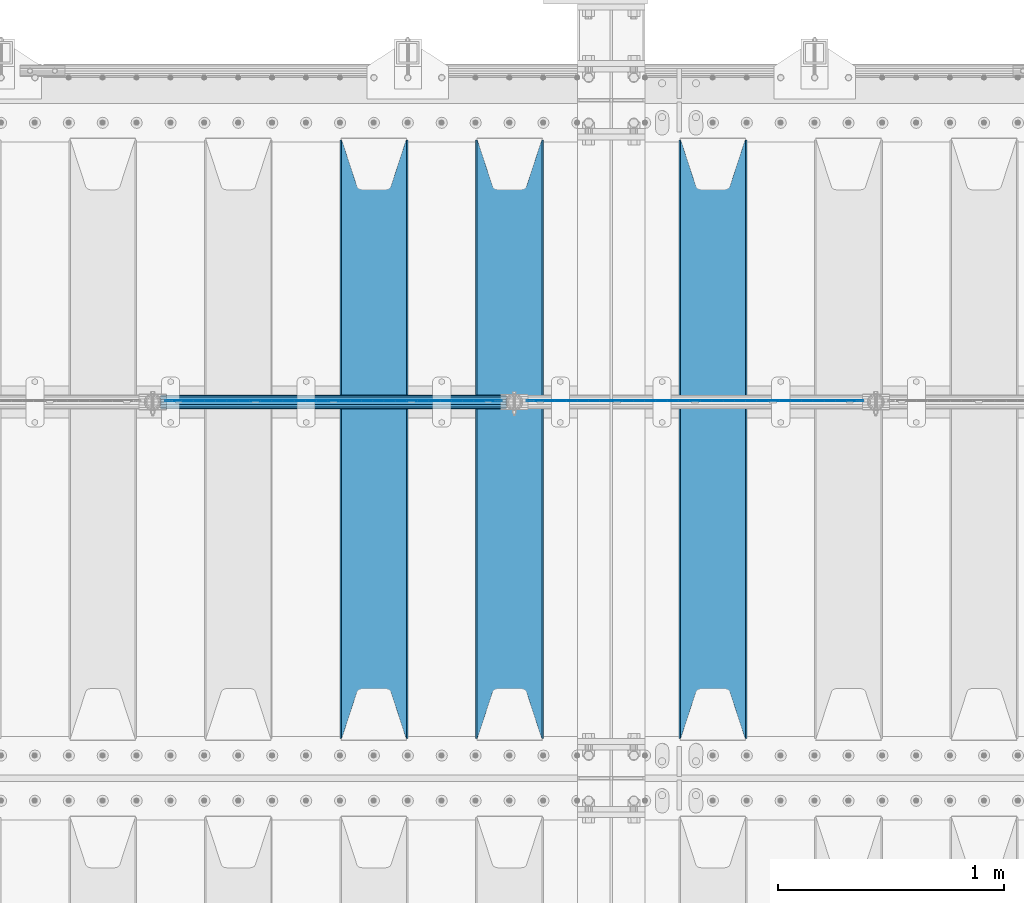
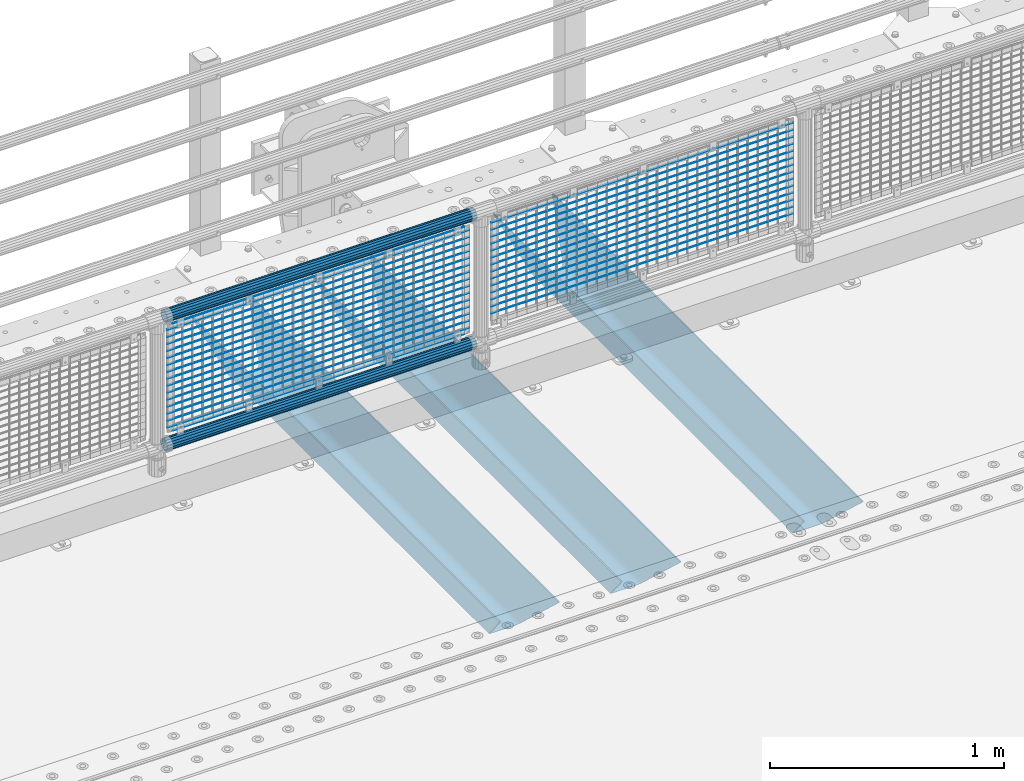
# One storey, part 127 of 247: 36 beams.
"""IFC2X3 building model written with IfcOpenShell, lengths in millimetres."""

from ifc_helpers import new_model, si_unit, frame, origin_with_axes, place, context, subcontext, project, spatial, faceted_brep, material, type_object, element, save


model = new_model("IFC2X3")

# Units and contexts
model_context = context("Model", 3, precision=1e-05, world=origin_with_axes())
body_context = subcontext(model_context, "Body", "Model", "MODEL_VIEW")
ifc_project = project(units=[si_unit("LENGTHUNIT", "METRE", prefix="MILLI"), si_unit("AREAUNIT", "SQUARE_METRE"), si_unit("VOLUMEUNIT", "CUBIC_METRE"), si_unit("MASSUNIT", "GRAM", prefix="KILO"), si_unit("TIMEUNIT", "SECOND"), si_unit("PLANEANGLEUNIT", "RADIAN"), si_unit("SOLIDANGLEUNIT", "STERADIAN"), si_unit("THERMODYNAMICTEMPERATUREUNIT", "DEGREE_CELSIUS"), si_unit("LUMINOUSINTENSITYUNIT", "LUMEN")], contexts=[model_context])

# Site, building, storey
site_placement = place(None, origin_with_axes())
site = spatial("IfcSite", under=ifc_project, at=site_placement, CompositionType="ELEMENT")
building_placement = place(site_placement, origin_with_axes())
building = spatial("IfcBuilding", under=site, at=building_placement, Name="Standard", CompositionType="ELEMENT")
storey_placement = place(building_placement, origin_with_axes())
storey = spatial("IfcBuildingStorey", under=building, at=storey_placement, Name="Undefined", CompositionType="ELEMENT", Elevation=0.0)

# Beams
ifc_material_1 = material(Name="STEEL/S355N")
beam_type_1 = type_object("IfcBeamType", PredefinedType="NOTDEFINED")
beam_1_placement = place(storey_placement, frame((12700.0, 6175.0, -115.0), z_axis=(0.0, 0.0, 1.0), x_axis=(0.0, 1.0, 0.0)))
element("IfcBeam", 1, at=beam_1_placement, inside=storey, type_object=beam_type_1, material=ifc_material_1, context=body_context, shape_type="Brep", body=[
    faceted_brep([(0.0, 150.0, 115.0), (0.0, 143.689999999999, 115.0), (2650.00000000297, 143.689999999999, 115.0), (2650.00000000297, 150.0, 115.0), (2650.00000000297, 142.059565218402, 110.0000000031), (2650.00000000297, 148.369565218403, 110.0000000031), (2441.90079219208, -80.1103600731112, -98.0992078077845), (2437.7588105432, -77.5672621345584, -102.241189456673), (2434.06523489746, -74.4080125315522, -105.934765102404), (2430.91086095089, -70.710272125576, -109.089139048974), (2428.37322971128, -66.5649389910068, -111.626770288588), (2426.51472138054, -62.0739139532889, -113.485278619323), (2425.38102192091, -57.3475956567672, -114.618978078955), (2424.99999999987, -52.5021667386536, -115.0), (2424.99999999987, 52.5021667386536, -115.0), (2425.38102192091, 57.3475956567672, -114.618978078955), (2426.51472138054, 62.0739139532889, -113.485278619323), (2428.37322971128, 66.5649389910068, -111.626770288588), (2430.91086095089, 70.710272125576, -109.089139048974), (2434.06523489746, 74.4080125315522, -105.934765102404), (2437.7588105432, 77.5672621345584, -102.241189456673), (2441.90079219208, 80.1103600731112, -98.0992078077846), (2446.38936140511, 81.9747917625791, -93.6106385947584), (2448.24948500409, 76.2713538057251, -91.7505149957729), (2444.62967112262, 74.76777986261, -95.3703288772456), (2441.28936334126, 72.7168944282894, -98.710636658607), (2438.31067330438, 70.1691124903846, -101.689326695487), (2435.76682334747, 67.1870637758839, -104.233176652398), (2433.72034654133, 63.8440531834895, -106.279653458539), (2432.22154950041, 60.222258798236, -107.778450499454), (2431.30727574265, 56.4107117849089, -108.692724257221), (2430.99999999987, 52.5031078186876, -109.0), (2430.99999999987, -52.5031078186876, -109.0), (2431.30727574265, -56.4107117849089, -108.692724257221), (2432.22154950041, -60.222258798236, -107.778450499454), (2433.72034654133, -63.8440531834895, -106.279653458539), (2435.76682334747, -67.1870637758839, -104.233176652398), (2438.31067330438, -70.1691124903846, -101.689326695487), (2441.28936334126, -72.7168944282894, -98.7106366586071), (2444.62967112262, -74.76777986261, -95.3703288772457), (2448.24948500409, -76.2713538057251, -91.7505149957729), (2650.00000000297, -142.059565218402, 110.0000000031), (2650.00000000297, -148.369565218403, 110.0000000031), (2446.38936140511, -81.9747917625791, -93.6106385947584), (2650.00000000297, -143.689999999999, 115.0), (2650.00000000297, -150.0, 115.0), (0.0, -143.689999999999, 115.0), (0.0, -150.0, 115.0), (0.0, -148.369565218261, 110.000000002663), (203.610638597422, -81.9747917625791, -93.6106385947584), (208.099207810448, -80.1103600731112, -98.0992078077845), (212.241189459336, -77.5672621345584, -102.241189456673), (215.934765105068, -74.4080125315522, -105.934765102404), (219.089139051637, -70.710272125576, -109.089139048974), (221.626770291251, -66.5649389910068, -111.626770288588), (223.485278621985, -62.0739139532889, -113.485278619323), (224.618978081617, -57.3475956567672, -114.618978078955), (225.000000002663, -52.5021667386536, -115.0), (225.000000002663, 52.5021667386536, -115.0), (224.618978081617, 57.3475956567672, -114.618978078955), (223.485278621985, 62.0739139532889, -113.485278619323), (221.626770291251, 66.5649389910068, -111.626770288588), (219.089139051637, 70.710272125576, -109.089139048974), (215.934765105068, 74.4080125315522, -105.934765102404), (212.241189459336, 77.5672621345584, -102.241189456673), (208.099207810448, 80.1103600731112, -98.0992078077846), (203.610638597422, 81.9747917625791, -93.6106385947584), (0.0, 148.369565218261, 110.000000002663), (0.0, 142.05956521826, 110.000000002663), (201.750514998436, 76.2713538057251, -91.7505149957729), (205.370328879908, 74.76777986261, -95.3703288772456), (208.710636661271, 72.7168944282894, -98.710636658607), (211.68932669815, 70.1691124903846, -101.689326695487), (214.233176655061, 67.1870637758839, -104.233176652398), (216.279653461202, 63.8440531834895, -106.279653458539), (217.778450502117, 60.222258798236, -107.778450499454), (218.692724259885, 56.4107117849089, -108.692724257221), (219.000000002663, 52.5031078186876, -109.0), (219.000000002663, -52.5031078186876, -109.0), (218.692724259885, -56.4107117849089, -108.692724257221), (217.778450502117, -60.222258798236, -107.778450499454), (216.279653461202, -63.8440531834895, -106.279653458539), (214.233176655061, -67.1870637758839, -104.233176652398), (211.68932669815, -70.1691124903846, -101.689326695487), (208.710636661271, -72.7168944282894, -98.7106366586071), (205.370328879908, -74.76777986261, -95.3703288772457), (201.750514998436, -76.2713538057251, -91.7505149957729), (0.0, -142.05956521826, 110.000000002663)], [[[0, 1, 2, 3]], [[3, 2, 4, 5]], [[6, 7, 8, 9, 10, 11, 12, 13, 14, 15, 16, 17, 18, 19, 20, 21, 22, 5, 4, 23, 24, 25, 26, 27, 28, 29, 30, 31, 32, 33, 34, 35, 36, 37, 38, 39, 40, 41, 42, 43]], [[44, 45, 42, 41]], [[46, 47, 45, 44]], [[43, 42, 45, 47, 48, 49]], [[6, 43, 49, 50]], [[7, 6, 50, 51]], [[8, 7, 51, 52]], [[9, 8, 52, 53]], [[10, 9, 53, 54]], [[11, 10, 54, 55]], [[12, 11, 55, 56]], [[13, 12, 56, 57]], [[14, 13, 57, 58]], [[15, 14, 58, 59]], [[16, 15, 59, 60]], [[17, 16, 60, 61]], [[18, 17, 61, 62]], [[19, 18, 62, 63]], [[20, 19, 63, 64]], [[21, 20, 64, 65]], [[22, 21, 65, 66]], [[0, 3, 5, 22, 66, 67]], [[1, 0, 67, 68]], [[23, 4, 2, 1, 68, 69]], [[24, 23, 69, 70]], [[25, 24, 70, 71]], [[26, 25, 71, 72]], [[27, 26, 72, 73]], [[28, 27, 73, 74]], [[29, 28, 74, 75]], [[30, 29, 75, 76]], [[31, 30, 76, 77]], [[32, 31, 77, 78]], [[33, 32, 78, 79]], [[34, 33, 79, 80]], [[35, 34, 80, 81]], [[36, 35, 81, 82]], [[37, 36, 82, 83]], [[38, 37, 83, 84]], [[39, 38, 84, 85]], [[40, 39, 85, 86]], [[46, 44, 41, 40, 86, 87]], [[47, 46, 87, 48]], [[86, 85, 84, 83, 82, 81, 80, 79, 78, 77, 76, 75, 74, 73, 72, 71, 70, 69, 68, 67, 66, 65, 64, 63, 62, 61, 60, 59, 58, 57, 56, 55, 54, 53, 52, 51, 50, 49, 48, 87]]]),
])
beam_2_placement = place(storey_placement, frame((11800.0, 6175.0, -115.0), z_axis=(0.0, 0.0, 1.0), x_axis=(0.0, 1.0, 0.0)))
element("IfcBeam", 2, at=beam_2_placement, inside=storey, type_object=beam_type_1, material=ifc_material_1, context=body_context, shape_type="Brep", body=[
    faceted_brep([(0.0, 150.0, 115.0), (0.0, 143.689999999999, 115.0), (2650.00000000297, 143.689999999999, 115.0), (2650.00000000297, 150.0, 115.0), (2650.00000000297, 142.059565218402, 110.0000000031), (2650.00000000297, 148.369565218403, 110.0000000031), (2441.90079219208, -80.1103600731112, -98.0992078077845), (2437.7588105432, -77.5672621345584, -102.241189456673), (2434.06523489746, -74.4080125315522, -105.934765102404), (2430.91086095089, -70.710272125576, -109.089139048974), (2428.37322971128, -66.5649389910068, -111.626770288588), (2426.51472138054, -62.0739139532889, -113.485278619323), (2425.38102192091, -57.3475956567672, -114.618978078955), (2424.99999999987, -52.5021667386536, -115.0), (2424.99999999987, 52.5021667386536, -115.0), (2425.38102192091, 57.3475956567672, -114.618978078955), (2426.51472138054, 62.0739139532889, -113.485278619323), (2428.37322971128, 66.5649389910068, -111.626770288588), (2430.91086095089, 70.710272125576, -109.089139048974), (2434.06523489746, 74.4080125315522, -105.934765102404), (2437.7588105432, 77.5672621345584, -102.241189456673), (2441.90079219208, 80.1103600731112, -98.0992078077846), (2446.38936140511, 81.9747917625791, -93.6106385947584), (2448.24948500409, 76.2713538057251, -91.7505149957729), (2444.62967112262, 74.76777986261, -95.3703288772456), (2441.28936334126, 72.7168944282894, -98.710636658607), (2438.31067330438, 70.1691124903846, -101.689326695487), (2435.76682334747, 67.1870637758839, -104.233176652398), (2433.72034654133, 63.8440531834895, -106.279653458539), (2432.22154950041, 60.222258798236, -107.778450499454), (2431.30727574265, 56.4107117849089, -108.692724257221), (2430.99999999987, 52.5031078186876, -109.0), (2430.99999999987, -52.5031078186876, -109.0), (2431.30727574265, -56.4107117849089, -108.692724257221), (2432.22154950041, -60.222258798236, -107.778450499454), (2433.72034654133, -63.8440531834895, -106.279653458539), (2435.76682334747, -67.1870637758839, -104.233176652398), (2438.31067330438, -70.1691124903846, -101.689326695487), (2441.28936334126, -72.7168944282894, -98.7106366586071), (2444.62967112262, -74.76777986261, -95.3703288772457), (2448.24948500409, -76.2713538057251, -91.7505149957729), (2650.00000000297, -142.059565218402, 110.0000000031), (2650.00000000297, -148.369565218403, 110.0000000031), (2446.38936140511, -81.9747917625791, -93.6106385947584), (2650.00000000297, -143.689999999999, 115.0), (2650.00000000297, -150.0, 115.0), (0.0, -143.689999999999, 115.0), (0.0, -150.0, 115.0), (0.0, -148.369565218261, 110.000000002663), (203.610638597422, -81.9747917625791, -93.6106385947584), (208.099207810448, -80.1103600731112, -98.0992078077845), (212.241189459336, -77.5672621345584, -102.241189456673), (215.934765105068, -74.4080125315522, -105.934765102404), (219.089139051637, -70.710272125576, -109.089139048974), (221.626770291251, -66.5649389910068, -111.626770288588), (223.485278621985, -62.0739139532889, -113.485278619323), (224.618978081617, -57.3475956567672, -114.618978078955), (225.000000002663, -52.5021667386536, -115.0), (225.000000002663, 52.5021667386536, -115.0), (224.618978081617, 57.3475956567672, -114.618978078955), (223.485278621985, 62.0739139532889, -113.485278619323), (221.626770291251, 66.5649389910068, -111.626770288588), (219.089139051637, 70.710272125576, -109.089139048974), (215.934765105068, 74.4080125315522, -105.934765102404), (212.241189459336, 77.5672621345584, -102.241189456673), (208.099207810448, 80.1103600731112, -98.0992078077846), (203.610638597422, 81.9747917625791, -93.6106385947584), (0.0, 148.369565218261, 110.000000002663), (0.0, 142.05956521826, 110.000000002663), (201.750514998436, 76.2713538057251, -91.7505149957729), (205.370328879908, 74.76777986261, -95.3703288772456), (208.710636661271, 72.7168944282894, -98.710636658607), (211.68932669815, 70.1691124903846, -101.689326695487), (214.233176655061, 67.1870637758839, -104.233176652398), (216.279653461202, 63.8440531834895, -106.279653458539), (217.778450502117, 60.222258798236, -107.778450499454), (218.692724259885, 56.4107117849089, -108.692724257221), (219.000000002663, 52.5031078186876, -109.0), (219.000000002663, -52.5031078186876, -109.0), (218.692724259885, -56.4107117849089, -108.692724257221), (217.778450502117, -60.222258798236, -107.778450499454), (216.279653461202, -63.8440531834895, -106.279653458539), (214.233176655061, -67.1870637758839, -104.233176652398), (211.68932669815, -70.1691124903846, -101.689326695487), (208.710636661271, -72.7168944282894, -98.7106366586071), (205.370328879908, -74.76777986261, -95.3703288772457), (201.750514998436, -76.2713538057251, -91.7505149957729), (0.0, -142.05956521826, 110.000000002663)], [[[0, 1, 2, 3]], [[3, 2, 4, 5]], [[6, 7, 8, 9, 10, 11, 12, 13, 14, 15, 16, 17, 18, 19, 20, 21, 22, 5, 4, 23, 24, 25, 26, 27, 28, 29, 30, 31, 32, 33, 34, 35, 36, 37, 38, 39, 40, 41, 42, 43]], [[44, 45, 42, 41]], [[46, 47, 45, 44]], [[43, 42, 45, 47, 48, 49]], [[6, 43, 49, 50]], [[7, 6, 50, 51]], [[8, 7, 51, 52]], [[9, 8, 52, 53]], [[10, 9, 53, 54]], [[11, 10, 54, 55]], [[12, 11, 55, 56]], [[13, 12, 56, 57]], [[14, 13, 57, 58]], [[15, 14, 58, 59]], [[16, 15, 59, 60]], [[17, 16, 60, 61]], [[18, 17, 61, 62]], [[19, 18, 62, 63]], [[20, 19, 63, 64]], [[21, 20, 64, 65]], [[22, 21, 65, 66]], [[0, 3, 5, 22, 66, 67]], [[1, 0, 67, 68]], [[23, 4, 2, 1, 68, 69]], [[24, 23, 69, 70]], [[25, 24, 70, 71]], [[26, 25, 71, 72]], [[27, 26, 72, 73]], [[28, 27, 73, 74]], [[29, 28, 74, 75]], [[30, 29, 75, 76]], [[31, 30, 76, 77]], [[32, 31, 77, 78]], [[33, 32, 78, 79]], [[34, 33, 79, 80]], [[35, 34, 80, 81]], [[36, 35, 81, 82]], [[37, 36, 82, 83]], [[38, 37, 83, 84]], [[39, 38, 84, 85]], [[40, 39, 85, 86]], [[46, 44, 41, 40, 86, 87]], [[47, 46, 87, 48]], [[86, 85, 84, 83, 82, 81, 80, 79, 78, 77, 76, 75, 74, 73, 72, 71, 70, 69, 68, 67, 66, 65, 64, 63, 62, 61, 60, 59, 58, 57, 56, 55, 54, 53, 52, 51, 50, 49, 48, 87]]]),
])
beam_3_placement = place(storey_placement, frame((11200.0, 6175.0, -115.0), z_axis=(0.0, 0.0, 1.0), x_axis=(0.0, 1.0, 0.0)))
element("IfcBeam", 3, at=beam_3_placement, inside=storey, type_object=beam_type_1, material=ifc_material_1, context=body_context, shape_type="Brep", body=[
    faceted_brep([(0.0, 150.0, 115.0), (0.0, 143.689999999999, 115.0), (2650.00000000297, 143.689999999999, 115.0), (2650.00000000297, 150.0, 115.0), (2650.00000000297, 142.059565218402, 110.0000000031), (2650.00000000297, 148.369565218403, 110.0000000031), (2441.90079219208, -80.1103600731112, -98.0992078077845), (2437.7588105432, -77.5672621345584, -102.241189456673), (2434.06523489746, -74.4080125315522, -105.934765102404), (2430.91086095089, -70.710272125576, -109.089139048974), (2428.37322971128, -66.5649389910068, -111.626770288588), (2426.51472138054, -62.0739139532889, -113.485278619323), (2425.38102192091, -57.3475956567672, -114.618978078955), (2424.99999999987, -52.5021667386536, -115.0), (2424.99999999987, 52.5021667386536, -115.0), (2425.38102192091, 57.3475956567672, -114.618978078955), (2426.51472138054, 62.0739139532889, -113.485278619323), (2428.37322971128, 66.5649389910068, -111.626770288588), (2430.91086095089, 70.710272125576, -109.089139048974), (2434.06523489746, 74.4080125315522, -105.934765102404), (2437.7588105432, 77.5672621345584, -102.241189456673), (2441.90079219208, 80.1103600731112, -98.0992078077846), (2446.38936140511, 81.9747917625791, -93.6106385947584), (2448.24948500409, 76.2713538057251, -91.7505149957729), (2444.62967112262, 74.76777986261, -95.3703288772456), (2441.28936334126, 72.7168944282894, -98.710636658607), (2438.31067330438, 70.1691124903846, -101.689326695487), (2435.76682334747, 67.1870637758839, -104.233176652398), (2433.72034654133, 63.8440531834895, -106.279653458539), (2432.22154950041, 60.222258798236, -107.778450499454), (2431.30727574265, 56.4107117849089, -108.692724257221), (2430.99999999987, 52.5031078186876, -109.0), (2430.99999999987, -52.5031078186876, -109.0), (2431.30727574265, -56.4107117849089, -108.692724257221), (2432.22154950041, -60.222258798236, -107.778450499454), (2433.72034654133, -63.8440531834895, -106.279653458539), (2435.76682334747, -67.1870637758839, -104.233176652398), (2438.31067330438, -70.1691124903846, -101.689326695487), (2441.28936334126, -72.7168944282894, -98.7106366586071), (2444.62967112262, -74.76777986261, -95.3703288772457), (2448.24948500409, -76.2713538057251, -91.7505149957729), (2650.00000000297, -142.059565218402, 110.0000000031), (2650.00000000297, -148.369565218403, 110.0000000031), (2446.38936140511, -81.9747917625791, -93.6106385947584), (2650.00000000297, -143.689999999999, 115.0), (2650.00000000297, -150.0, 115.0), (0.0, -143.689999999999, 115.0), (0.0, -150.0, 115.0), (0.0, -148.369565218261, 110.000000002663), (203.610638597422, -81.9747917625791, -93.6106385947584), (208.099207810448, -80.1103600731112, -98.0992078077845), (212.241189459336, -77.5672621345584, -102.241189456673), (215.934765105068, -74.4080125315522, -105.934765102404), (219.089139051637, -70.710272125576, -109.089139048974), (221.626770291251, -66.5649389910068, -111.626770288588), (223.485278621985, -62.0739139532889, -113.485278619323), (224.618978081617, -57.3475956567672, -114.618978078955), (225.000000002663, -52.5021667386536, -115.0), (225.000000002663, 52.5021667386536, -115.0), (224.618978081617, 57.3475956567672, -114.618978078955), (223.485278621985, 62.0739139532889, -113.485278619323), (221.626770291251, 66.5649389910068, -111.626770288588), (219.089139051637, 70.710272125576, -109.089139048974), (215.934765105068, 74.4080125315522, -105.934765102404), (212.241189459336, 77.5672621345584, -102.241189456673), (208.099207810448, 80.1103600731112, -98.0992078077846), (203.610638597422, 81.9747917625791, -93.6106385947584), (0.0, 148.369565218261, 110.000000002663), (0.0, 142.05956521826, 110.000000002663), (201.750514998436, 76.2713538057251, -91.7505149957729), (205.370328879908, 74.76777986261, -95.3703288772456), (208.710636661271, 72.7168944282894, -98.710636658607), (211.68932669815, 70.1691124903846, -101.689326695487), (214.233176655061, 67.1870637758839, -104.233176652398), (216.279653461202, 63.8440531834895, -106.279653458539), (217.778450502117, 60.222258798236, -107.778450499454), (218.692724259885, 56.4107117849089, -108.692724257221), (219.000000002663, 52.5031078186876, -109.0), (219.000000002663, -52.5031078186876, -109.0), (218.692724259885, -56.4107117849089, -108.692724257221), (217.778450502117, -60.222258798236, -107.778450499454), (216.279653461202, -63.8440531834895, -106.279653458539), (214.233176655061, -67.1870637758839, -104.233176652398), (211.68932669815, -70.1691124903846, -101.689326695487), (208.710636661271, -72.7168944282894, -98.7106366586071), (205.370328879908, -74.76777986261, -95.3703288772457), (201.750514998436, -76.2713538057251, -91.7505149957729), (0.0, -142.05956521826, 110.000000002663)], [[[0, 1, 2, 3]], [[3, 2, 4, 5]], [[6, 7, 8, 9, 10, 11, 12, 13, 14, 15, 16, 17, 18, 19, 20, 21, 22, 5, 4, 23, 24, 25, 26, 27, 28, 29, 30, 31, 32, 33, 34, 35, 36, 37, 38, 39, 40, 41, 42, 43]], [[44, 45, 42, 41]], [[46, 47, 45, 44]], [[43, 42, 45, 47, 48, 49]], [[6, 43, 49, 50]], [[7, 6, 50, 51]], [[8, 7, 51, 52]], [[9, 8, 52, 53]], [[10, 9, 53, 54]], [[11, 10, 54, 55]], [[12, 11, 55, 56]], [[13, 12, 56, 57]], [[14, 13, 57, 58]], [[15, 14, 58, 59]], [[16, 15, 59, 60]], [[17, 16, 60, 61]], [[18, 17, 61, 62]], [[19, 18, 62, 63]], [[20, 19, 63, 64]], [[21, 20, 64, 65]], [[22, 21, 65, 66]], [[0, 3, 5, 22, 66, 67]], [[1, 0, 67, 68]], [[23, 4, 2, 1, 68, 69]], [[24, 23, 69, 70]], [[25, 24, 70, 71]], [[26, 25, 71, 72]], [[27, 26, 72, 73]], [[28, 27, 73, 74]], [[29, 28, 74, 75]], [[30, 29, 75, 76]], [[31, 30, 76, 77]], [[32, 31, 77, 78]], [[33, 32, 78, 79]], [[34, 33, 79, 80]], [[35, 34, 80, 81]], [[36, 35, 81, 82]], [[37, 36, 82, 83]], [[38, 37, 83, 84]], [[39, 38, 84, 85]], [[40, 39, 85, 86]], [[46, 44, 41, 40, 86, 87]], [[47, 46, 87, 48]], [[86, 85, 84, 83, 82, 81, 80, 79, 78, 77, 76, 75, 74, 73, 72, 71, 70, 69, 68, 67, 66, 65, 64, 63, 62, 61, 60, 59, 58, 57, 56, 55, 54, 53, 52, 51, 50, 49, 48, 87]]]),
])
ifc_material_2 = material()
beam_type_2 = type_object("IfcBeamType", PredefinedType="NOTDEFINED")
beam_4_placement = place(storey_placement, frame((10255.85, 7664.5, 298.170000000005), z_axis=(0.0, 0.0, 1.0), x_axis=(1.0, 0.0, 0.0)))
element("IfcBeam", 4, at=beam_4_placement, inside=storey, type_object=beam_type_2, material=ifc_material_2, context=body_context, shape_type="Brep", body=[
    faceted_brep([(0.0, -25.3500000000004, 0.0), (0.0, -23.4203461491616, 9.70102501045585), (1530.0, -23.4203461491616, 9.70102501045506), (1530.0, -25.3500000000004, 0.0), (0.0, -17.9251569030794, 17.9251569030785), (1530.0, -17.9251569030794, 17.925156903079), (0.0, -9.70102501045494, 23.4203461491616), (1530.0, -9.70102501045494, 23.4203461491611), (0.0, 0.0, 25.3500000000004), (1530.0, 0.0, 25.35), (0.0, 9.70102501045494, 23.4203461491616), (1530.0, 9.70102501045494, 23.4203461491611), (0.0, 17.9251569030794, 17.9251569030785), (1530.0, 17.9251569030794, 17.925156903079), (0.0, 23.4203461491616, 9.70102501045585), (1530.0, 23.4203461491616, 9.70102501045506), (0.0, 25.3500000000004, 0.0), (1530.0, 25.3500000000004, 0.0), (0.0, 23.4203461491616, -9.70102501045585), (1530.0, 23.4203461491616, -9.70102501045506), (0.0, 17.9251569030794, -17.9251569030785), (1530.0, 17.9251569030794, -17.925156903079), (0.0, 9.70102501045494, -23.4203461491616), (1530.0, 9.70102501045494, -23.4203461491611), (0.0, 0.0, -25.3500000000004), (1530.0, 0.0, -25.35), (0.0, -9.70102501045494, -23.4203461491616), (1530.0, -9.70102501045494, -23.4203461491611), (0.0, -17.9251569030794, -17.9251569030785), (1530.0, -17.9251569030794, -17.925156903079), (0.0, -23.4203461491616, -9.70102501045585), (1530.0, -23.4203461491616, -9.70102501045506), (0.0, -30.1499999999996, 0.0), (0.0, -27.8549679052148, -11.5379054858076), (1530.0, -27.8549679052148, -11.5379054858075), (1530.0, -30.1499999999996, 0.0), (0.0, -21.3192694527743, -21.3192694527752), (1530.0, -21.3192694527743, -21.3192694527744), (0.0, -11.5379054858076, -27.8549679052157), (1530.0, -11.5379054858076, -27.8549679052153), (0.0, 0.0, -30.1499999999996), (1530.0, 0.0, -30.15), (0.0, 11.5379054858076, -27.8549679052157), (1530.0, 11.5379054858076, -27.8549679052153), (0.0, 21.3192694527743, -21.3192694527752), (1530.0, 21.3192694527743, -21.3192694527744), (0.0, 27.8549679052157, -11.5379054858076), (1530.0, 27.8549679052157, -11.5379054858074), (0.0, 30.1499999999996, 0.0), (1530.0, 30.1499999999996, 0.0), (0.0, 27.8549679052157, 11.5379054858076), (1530.0, 27.8549679052157, 11.5379054858074), (0.0, 21.3192694527743, 21.3192694527752), (1530.0, 21.3192694527743, 21.3192694527744), (0.0, 11.5379054858076, 27.8549679052157), (1530.0, 11.5379054858076, 27.8549679052153), (0.0, 0.0, 30.1499999999996), (1530.0, 0.0, 30.15), (0.0, -11.5379054858076, 27.8549679052157), (1530.0, -11.5379054858076, 27.8549679052153), (0.0, -21.3192694527743, 21.3192694527752), (1530.0, -21.3192694527743, 21.3192694527744), (0.0, -27.8549679052157, 11.5379054858076), (1530.0, -27.8549679052157, 11.5379054858074)], [[[0, 1, 2, 3]], [[1, 4, 5, 2]], [[4, 6, 7, 5]], [[6, 8, 9, 7]], [[8, 10, 11, 9]], [[10, 12, 13, 11]], [[12, 14, 15, 13]], [[14, 16, 17, 15]], [[16, 18, 19, 17]], [[18, 20, 21, 19]], [[20, 22, 23, 21]], [[22, 24, 25, 23]], [[24, 26, 27, 25]], [[26, 28, 29, 27]], [[28, 30, 31, 29]], [[30, 0, 3, 31]], [[32, 33, 34, 35]], [[33, 36, 37, 34]], [[36, 38, 39, 37]], [[38, 40, 41, 39]], [[40, 42, 43, 41]], [[42, 44, 45, 43]], [[44, 46, 47, 45]], [[46, 48, 49, 47]], [[48, 50, 51, 49]], [[50, 52, 53, 51]], [[52, 54, 55, 53]], [[54, 56, 57, 55]], [[56, 58, 59, 57]], [[58, 60, 61, 59]], [[60, 62, 63, 61]], [[62, 32, 35, 63]], [[37, 39, 41, 43, 45, 47, 49, 51, 53, 55, 57, 59, 61, 63, 35, 34], [5, 7, 9, 11, 13, 15, 17, 19, 21, 23, 25, 27, 29, 31, 3, 2]], [[62, 60, 58, 56, 54, 52, 50, 48, 46, 44, 42, 40, 38, 36, 33, 32], [30, 28, 26, 24, 22, 20, 18, 16, 14, 12, 10, 8, 6, 4, 1, 0]]]),
])
beam_5_placement = place(storey_placement, frame((10255.85, 7664.5, 969.850000000004), z_axis=(0.0, 0.0, 1.0), x_axis=(1.0, 0.0, 0.0)))
element("IfcBeam", 5, at=beam_5_placement, inside=storey, type_object=beam_type_2, material=ifc_material_2, context=body_context, shape_type="Brep", body=[
    faceted_brep([(0.0, -25.3500000000004, 0.0), (0.0, -23.4203461491616, 9.70102501045585), (1530.0, -23.4203461491616, 9.70102501045506), (1530.0, -25.3500000000004, 0.0), (0.0, -17.9251569030794, 17.9251569030785), (1530.0, -17.9251569030794, 17.925156903079), (0.0, -9.70102501045494, 23.4203461491616), (1530.0, -9.70102501045494, 23.4203461491611), (0.0, 0.0, 25.3500000000004), (1530.0, 0.0, 25.35), (0.0, 9.70102501045494, 23.4203461491616), (1530.0, 9.70102501045494, 23.4203461491611), (0.0, 17.9251569030794, 17.9251569030785), (1530.0, 17.9251569030794, 17.925156903079), (0.0, 23.4203461491616, 9.70102501045585), (1530.0, 23.4203461491616, 9.70102501045506), (0.0, 25.3500000000004, 0.0), (1530.0, 25.3500000000004, 0.0), (0.0, 23.4203461491616, -9.70102501045585), (1530.0, 23.4203461491616, -9.70102501045506), (0.0, 17.9251569030794, -17.9251569030785), (1530.0, 17.9251569030794, -17.925156903079), (0.0, 9.70102501045494, -23.4203461491616), (1530.0, 9.70102501045494, -23.4203461491611), (0.0, 0.0, -25.3500000000004), (1530.0, 0.0, -25.35), (0.0, -9.70102501045494, -23.4203461491616), (1530.0, -9.70102501045494, -23.4203461491611), (0.0, -17.9251569030794, -17.9251569030785), (1530.0, -17.9251569030794, -17.925156903079), (0.0, -23.4203461491616, -9.70102501045585), (1530.0, -23.4203461491616, -9.70102501045506), (0.0, -30.1499999999996, 0.0), (0.0, -27.8549679052148, -11.5379054858076), (1530.0, -27.8549679052148, -11.5379054858075), (1530.0, -30.1499999999996, 0.0), (0.0, -21.3192694527743, -21.3192694527752), (1530.0, -21.3192694527743, -21.3192694527744), (0.0, -11.5379054858076, -27.8549679052157), (1530.0, -11.5379054858076, -27.8549679052153), (0.0, 0.0, -30.1499999999996), (1530.0, 0.0, -30.15), (0.0, 11.5379054858076, -27.8549679052157), (1530.0, 11.5379054858076, -27.8549679052153), (0.0, 21.3192694527743, -21.3192694527752), (1530.0, 21.3192694527743, -21.3192694527744), (0.0, 27.8549679052157, -11.5379054858076), (1530.0, 27.8549679052157, -11.5379054858074), (0.0, 30.1499999999996, 0.0), (1530.0, 30.1499999999996, 0.0), (0.0, 27.8549679052157, 11.5379054858076), (1530.0, 27.8549679052157, 11.5379054858074), (0.0, 21.3192694527743, 21.3192694527752), (1530.0, 21.3192694527743, 21.3192694527744), (0.0, 11.5379054858076, 27.8549679052157), (1530.0, 11.5379054858076, 27.8549679052153), (0.0, 0.0, 30.1499999999996), (1530.0, 0.0, 30.15), (0.0, -11.5379054858076, 27.8549679052157), (1530.0, -11.5379054858076, 27.8549679052153), (0.0, -21.3192694527743, 21.3192694527752), (1530.0, -21.3192694527743, 21.3192694527744), (0.0, -27.8549679052157, 11.5379054858076), (1530.0, -27.8549679052157, 11.5379054858074)], [[[0, 1, 2, 3]], [[1, 4, 5, 2]], [[4, 6, 7, 5]], [[6, 8, 9, 7]], [[8, 10, 11, 9]], [[10, 12, 13, 11]], [[12, 14, 15, 13]], [[14, 16, 17, 15]], [[16, 18, 19, 17]], [[18, 20, 21, 19]], [[20, 22, 23, 21]], [[22, 24, 25, 23]], [[24, 26, 27, 25]], [[26, 28, 29, 27]], [[28, 30, 31, 29]], [[30, 0, 3, 31]], [[32, 33, 34, 35]], [[33, 36, 37, 34]], [[36, 38, 39, 37]], [[38, 40, 41, 39]], [[40, 42, 43, 41]], [[42, 44, 45, 43]], [[44, 46, 47, 45]], [[46, 48, 49, 47]], [[48, 50, 51, 49]], [[50, 52, 53, 51]], [[52, 54, 55, 53]], [[54, 56, 57, 55]], [[56, 58, 59, 57]], [[58, 60, 61, 59]], [[60, 62, 63, 61]], [[62, 32, 35, 63]], [[37, 39, 41, 43, 45, 47, 49, 51, 53, 55, 57, 59, 61, 63, 35, 34], [5, 7, 9, 11, 13, 15, 17, 19, 21, 23, 25, 27, 29, 31, 3, 2]], [[62, 60, 58, 56, 54, 52, 50, 48, 46, 44, 42, 40, 38, 36, 33, 32], [30, 28, 26, 24, 22, 20, 18, 16, 14, 12, 10, 8, 6, 4, 1, 0]]]),
])
ifc_material_3 = material(Name="Misc_Undefined")
beam_type_3 = type_object("IfcBeamType", Name="D3", PredefinedType="NOTDEFINED")
for number, where, z_axis, x_axis in (
    (6, (11876.0, 7670.50000000001, 851.597000000005), (0.0, 0.0, 1.0), (1.0, 0.0, 0.0)),
    (7, (11876.0, 7670.50000000001, 669.452000000005), (0.0, 0.0, 1.0), (1.0, 0.0, 0.0)),
    (8, (11876.0, 7670.50000000001, 523.736000000005), (0.0, 0.0, 1.0), (1.0, 0.0, 0.0)),
    (9, (11876.0, 7670.50000000001, 487.307000000005), (0.0, 0.0, 1.0), (1.0, 0.0, 0.0)),
    (10, (11876.0, 7670.50000000001, 705.881000000005), (0.0, 0.0, 1.0), (1.0, 0.0, 0.0)),
    (11, (11876.0, 7670.50000000001, 596.594000000005), (0.0, 0.0, 1.0), (1.0, 0.0, 0.0)),
    (12, (11876.0, 7670.50000000001, 450.878000000005), (0.0, 0.0, 1.0), (1.0, 0.0, 0.0)),
    (13, (11876.0, 7670.50000000001, 815.168000000005), (0.0, 0.0, 1.0), (1.0, 0.0, 0.0)),
    (14, (11876.0, 7670.50000000001, 888.026000000005), (0.0, 0.0, 1.0), (1.0, 0.0, 0.0)),
    (15, (11876.0, 7670.50000000001, 778.739000000005), (0.0, 0.0, 1.0), (1.0, 0.0, 0.0)),
    (16, (11876.0, 7670.50000000001, 742.310000000005), (0.0, 0.0, 1.0), (1.0, 0.0, 0.0)),
    (17, (11876.0, 7670.50000000001, 633.023000000005), (0.0, 0.0, 1.0), (1.0, 0.0, 0.0)),
    (18, (11876.0, 7670.50000000001, 560.165000000005), (0.0, 0.0, 1.0), (1.0, 0.0, 0.0)),
    (19, (11876.0, 7670.50000000001, 414.449000000005), (0.0, 0.0, 1.0), (1.0, 0.0, 0.0)),
    (20, (10276.0, 7670.5, 851.597000000004), (0.0, 0.0, 1.0), (1.0, 0.0, 0.0)),
    (21, (10276.0, 7670.5, 669.452000000004), (0.0, 0.0, 1.0), (1.0, 0.0, 0.0)),
    (22, (10276.0, 7670.5, 523.736000000004), (0.0, 0.0, 1.0), (1.0, 0.0, 0.0)),
    (23, (10276.0, 7670.5, 487.307000000004), (0.0, 0.0, 1.0), (1.0, 0.0, 0.0)),
    (24, (10276.0, 7670.5, 705.881000000004), (0.0, 0.0, 1.0), (1.0, 0.0, 0.0)),
    (25, (10276.0, 7670.5, 596.594000000004), (0.0, 0.0, 1.0), (1.0, 0.0, 0.0)),
    (26, (10276.0, 7670.5, 450.878000000004), (0.0, 0.0, 1.0), (1.0, 0.0, 0.0)),
    (27, (10276.0, 7670.5, 815.168000000004), (0.0, 0.0, 1.0), (1.0, 0.0, 0.0)),
    (28, (10276.0, 7670.5, 888.026000000004), (0.0, 0.0, 1.0), (1.0, 0.0, 0.0)),
    (29, (10276.0, 7670.5, 778.739000000004), (0.0, 0.0, 1.0), (1.0, 0.0, 0.0)),
    (30, (10276.0, 7670.5, 742.310000000004), (0.0, 0.0, 1.0), (1.0, 0.0, 0.0)),
    (31, (10276.0, 7670.5, 633.023000000004), (0.0, 0.0, 1.0), (1.0, 0.0, 0.0)),
    (32, (10276.0, 7670.5, 560.165000000004), (0.0, 0.0, 1.0), (1.0, 0.0, 0.0)),
    (33, (10276.0, 7670.5, 414.449000000004), (0.0, 0.0, 1.0), (1.0, 0.0, 0.0)),
):
    element("IfcBeam", number, at=place(storey_placement, frame(where, z_axis=z_axis, x_axis=x_axis)), inside=storey, type_object=beam_type_3, material=ifc_material_3, ObjectType="D3", context=body_context, shape_type="Brep", body=[
        faceted_brep([(1.81898940354586e-12, -1.5, -5.6843418860808e-14), (0.0, -0.75, -1.29903810567703), (1490.0, -0.75, -1.29903810567669), (1490.0, -1.5, 0.0), (0.0, 0.75, -1.29903810567703), (1490.0, 0.75, -1.29903810567669), (1.81898940354586e-12, 1.5, -5.6843418860808e-14), (1490.0, 1.5, 0.0), (0.0, 0.75, 1.29903810567703), (1490.0, 0.75, 1.29903810567669), (0.0, -0.75, 1.29903810567703), (1490.0, -0.75, 1.29903810567669)], [[[0, 1, 2, 3]], [[1, 4, 5, 2]], [[4, 6, 7, 5]], [[6, 8, 9, 7]], [[8, 10, 11, 9]], [[10, 0, 3, 11]], [[5, 7, 9, 11, 3, 2]], [[10, 8, 6, 4, 1, 0]]]),
    ])
beam_6_placement = place(storey_placement, frame((10301.0, 7670.5, 353.020000000004), z_axis=(0.0, 0.0, 1.0), x_axis=(1.0, 0.0, 0.0)))
element("IfcBeam", 34, at=beam_6_placement, inside=storey, type_object=beam_type_3, material=ifc_material_3, ObjectType="D3", context=body_context, shape_type="Brep", body=[
    faceted_brep([(1.81898940354586e-12, -1.5, -5.6843418860808e-14), (0.0, -0.75, -1.29903810567703), (1440.0, -0.75, -1.29903810567669), (1440.0, -1.5, 0.0), (0.0, 0.75, -1.29903810567703), (1440.0, 0.75, -1.29903810567663), (1.81898940354586e-12, 1.5, -5.6843418860808e-14), (1440.0, 1.5, 0.0), (0.0, 0.75, 1.29903810567703), (1440.0, 0.75, 1.29903810567669), (0.0, -0.75, 1.29903810567703), (1440.0, -0.75, 1.29903810567669)], [[[0, 1, 2, 3]], [[1, 4, 5, 2]], [[4, 6, 7, 5]], [[6, 8, 9, 7]], [[8, 10, 11, 9]], [[10, 0, 3, 11]], [[5, 7, 9, 11, 3, 2]], [[10, 8, 6, 4, 1, 0]]]),
])
beam_7_placement = place(storey_placement, frame((10276.0, 7670.5, 378.020000000004), z_axis=(0.0, 0.0, 1.0), x_axis=(1.0, 0.0, 0.0)))
element("IfcBeam", 35, at=beam_7_placement, inside=storey, type_object=beam_type_3, material=ifc_material_3, ObjectType="D3", context=body_context, shape_type="Brep", body=[
    faceted_brep([(1.81898940354586e-12, -1.5, -5.6843418860808e-14), (0.0, -0.75, -1.29903810567703), (1490.0, -0.75, -1.29903810567669), (1490.0, -1.5, 0.0), (0.0, 0.75, -1.29903810567703), (1490.0, 0.75, -1.29903810567669), (1.81898940354586e-12, 1.5, -5.6843418860808e-14), (1490.0, 1.5, 0.0), (0.0, 0.75, 1.29903810567703), (1490.0, 0.75, 1.29903810567669), (0.0, -0.75, 1.29903810567703), (1490.0, -0.75, 1.29903810567669)], [[[0, 1, 2, 3]], [[1, 4, 5, 2]], [[4, 6, 7, 5]], [[6, 8, 9, 7]], [[8, 10, 11, 9]], [[10, 0, 3, 11]], [[5, 7, 9, 11, 3, 2]], [[10, 8, 6, 4, 1, 0]]]),
])
beam_8_placement = place(storey_placement, frame((10301.0, 7670.5, 913.020000000004), z_axis=(0.0, 0.0, 1.0), x_axis=(1.0, 0.0, 0.0)))
element("IfcBeam", 36, at=beam_8_placement, inside=storey, type_object=beam_type_3, material=ifc_material_3, ObjectType="D3", context=body_context, shape_type="Brep", body=[
    faceted_brep([(1.81898940354586e-12, -1.5, -5.6843418860808e-14), (0.0, -0.75, -1.29903810567703), (1440.0, -0.75, -1.29903810567669), (1440.0, -1.5, 0.0), (0.0, 0.75, -1.29903810567703), (1440.0, 0.75, -1.29903810567663), (1.81898940354586e-12, 1.5, -5.6843418860808e-14), (1440.0, 1.5, 0.0), (0.0, 0.75, 1.29903810567703), (1440.0, 0.75, 1.29903810567669), (0.0, -0.75, 1.29903810567703), (1440.0, -0.75, 1.29903810567669)], [[[0, 1, 2, 3]], [[1, 4, 5, 2]], [[4, 6, 7, 5]], [[6, 8, 9, 7]], [[8, 10, 11, 9]], [[10, 0, 3, 11]], [[5, 7, 9, 11, 3, 2]], [[10, 8, 6, 4, 1, 0]]]),
])

save(model, "model.ifc")
